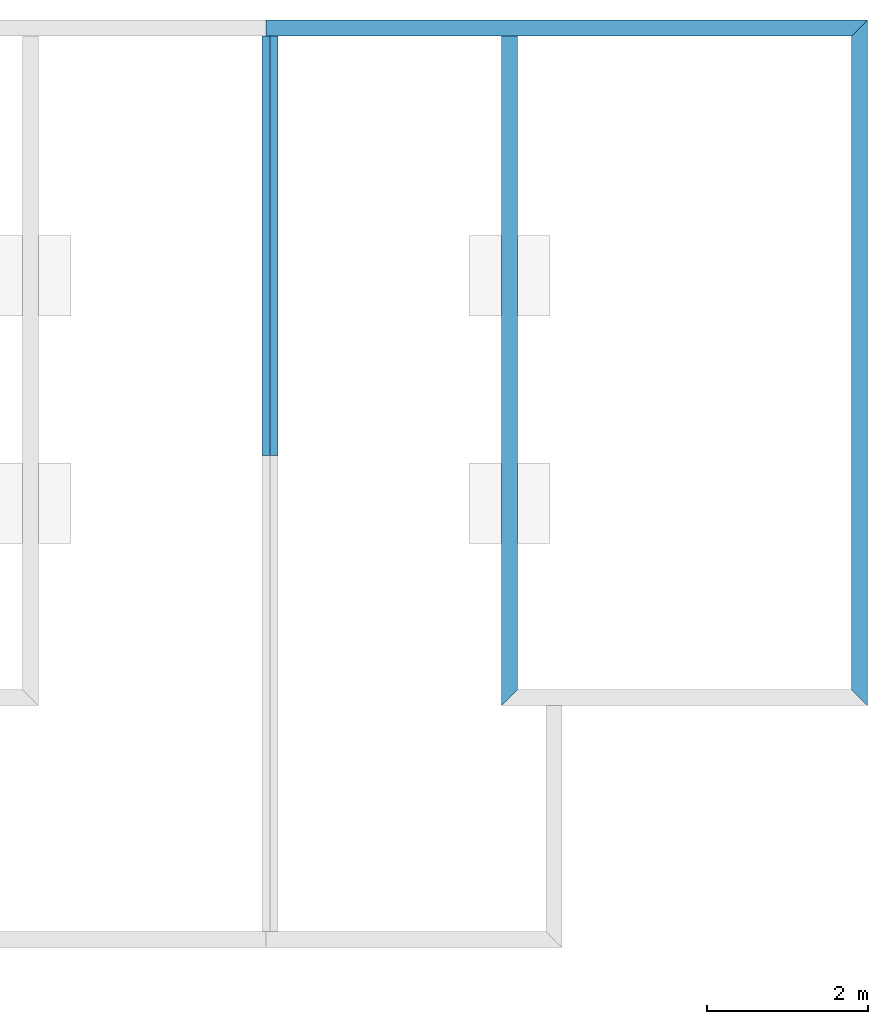
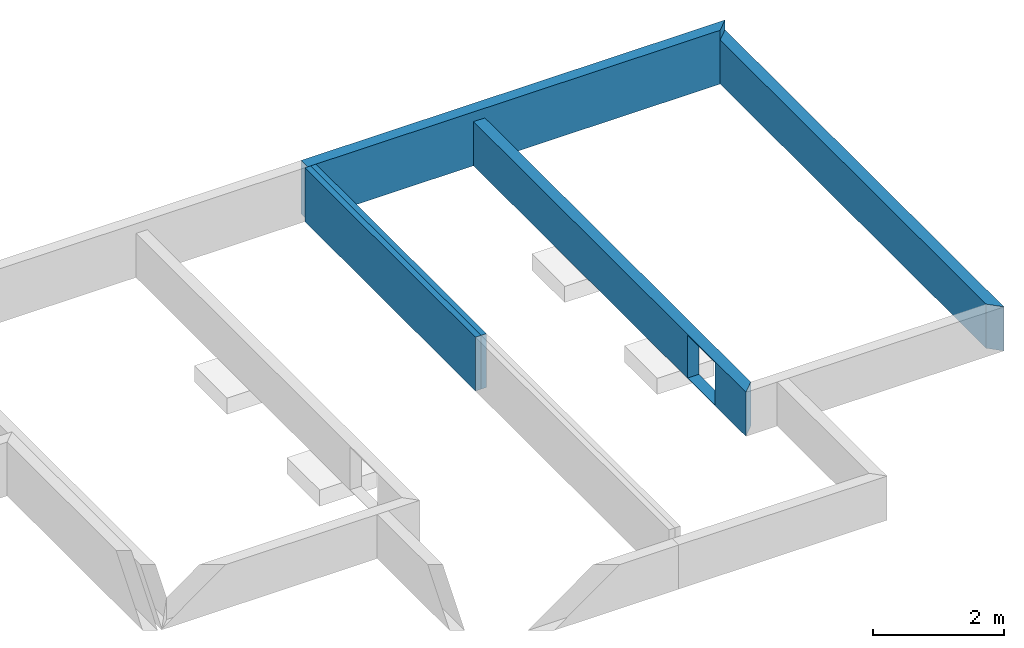
# One storey, part 2 of 2: 5 walls, 1 opening.
"""IFC2X3 building model written with IfcOpenShell, lengths in metres."""

from ifc_helpers import new_model, entity, si_unit, converted_unit, derived_unit, money_unit, direction, frame, origin_with_axes, origin_2d_with_axis, place, context, subcontext, project, spatial, polyline, rectangle, outline, extrude, clip, halfspace, material, layer, layer_set, layer_usage, type_object, element, save


model = new_model("IFC2X3")

# Units and contexts
model_context = context("Model", 3, precision=1e-05, world=origin_with_axes(), true_north=direction((0.0, 1.0)))
body_context = subcontext(model_context, "Body", "Model", "MODEL_VIEW")
ifc_project = project(units=[si_unit("LENGTHUNIT", "METRE"), si_unit("AREAUNIT", "SQUARE_METRE"), si_unit("VOLUMEUNIT", "CUBIC_METRE"), converted_unit("PLANEANGLEUNIT", "DEGREE", entity("IfcPlaneAngleMeasure", 0.0174532925199), si_unit("PLANEANGLEUNIT", "RADIAN"), dimensions=[0, 0, 0, 0, 0, 0, 0]), si_unit("SOLIDANGLEUNIT", "STERADIAN"), money_unit("CHF"), converted_unit("TIMEUNIT", "Year", entity("IfcTimeMeasure", 31556926.0), si_unit("TIMEUNIT", "SECOND"), dimensions=[0, 0, 1, 0, 0, 0, 0]), si_unit("MASSUNIT", "GRAM", prefix="KILO"), si_unit("THERMODYNAMICTEMPERATUREUNIT", "DEGREE_CELSIUS"), si_unit("LUMINOUSINTENSITYUNIT", "LUMEN"), si_unit("ENERGYUNIT", "JOULE", prefix="MEGA"), derived_unit("THERMALCONDUCTANCEUNIT", [(si_unit("POWERUNIT", "WATT"), 1), (si_unit("LENGTHUNIT", "METRE"), -1), (si_unit("THERMODYNAMICTEMPERATUREUNIT", "KELVIN"), -1)]), derived_unit("SPECIFICHEATCAPACITYUNIT", [(si_unit("ENERGYUNIT", "JOULE"), 1), (si_unit("MASSUNIT", "GRAM", prefix="KILO"), -1), (si_unit("THERMODYNAMICTEMPERATUREUNIT", "KELVIN"), -1)]), derived_unit("MASSDENSITYUNIT", [(si_unit("MASSUNIT", "GRAM", prefix="KILO"), 1), (si_unit("VOLUMEUNIT", "CUBIC_METRE"), -1)])], contexts=[model_context])

# Site, building, storey
site_placement = place(None, origin_with_axes())
site = spatial("IfcSite", under=ifc_project, at=site_placement, CompositionType="ELEMENT")
building_placement = place(site_placement, origin_with_axes())
building = spatial("IfcBuilding", under=site, at=building_placement, CompositionType="ELEMENT")
storey_placement = place(building_placement, frame((0.0, 0.0, -0.8), z_axis=(0.0, 0.0, 1.0), x_axis=(1.0, 0.0, 0.0)))
storey = spatial("IfcBuildingStorey", under=building, at=storey_placement, Name="vs", CompositionType="ELEMENT", Elevation=-0.8)

# Walls
ifc_material = material(Name="Parpaing")
ifc_layer_1 = layer(ifc_material, 0.2, ventilated="UNKNOWN")
ifc_layer_set_1 = layer_set([ifc_layer_1], Name="Parpaing 0.2")
ifc_layer_usage_1 = layer_usage(ifc_layer_set_1, "AXIS2", "POSITIVE", -0.1)
wall_type_1 = type_object("IfcWallType", Name="Mur de base:Ext. Parpaing 20", PredefinedType="STANDARD")
wall_1_placement = place(storey_placement, frame((83.6810189554, 92.347523968, -0.2), z_axis=(0.0, 0.0, 1.0), x_axis=(1.0, 0.0, 0.0)))
element("IfcWallStandardCase", 1, at=wall_1_placement, inside=storey, type_object=wall_type_1, material=ifc_layer_usage_1, Name="Mur de base:Ext. Parpaing 20", ObjectType="STANDARD", context=body_context, shape_type="SweptSolid", body=[
    extrude(outline(polyline([(0.0, -0.1), (7.25402976813, -0.1), (7.45402976813, 0.1), (0.0, 0.1), (0.0, -0.1)])), origin_with_axes(), (0.0, 0.0, 1.0), 1.0),
])
ifc_layer_usage_2 = layer_usage(ifc_layer_set_1, "AXIS2", "POSITIVE", -0.1)
wall_2_placement = place(storey_placement, frame((91.0350487235, 92.347523968, -0.2), z_axis=(0.0, 0.0, 1.0), x_axis=(0.0, -1.0, 0.0)))
element("IfcWallStandardCase", 2, at=wall_2_placement, inside=storey, type_object=wall_type_1, material=ifc_layer_usage_2, Name="Mur de base:Ext. Parpaing 20", ObjectType="STANDARD", context=body_context, shape_type="SweptSolid", body=[
    extrude(outline(polyline([(0.1, -0.1), (8.2, -0.1), (8.4, 0.1), (-0.1, 0.1), (0.1, -0.1)])), origin_with_axes(), (0.0, 0.0, 1.0), 0.82),
])

# Wall, opening
ifc_layer_usage_3 = layer_usage(ifc_layer_set_1, "AXIS2", "POSITIVE", -0.1)
wall_3_placement = place(storey_placement, frame((86.696785775, 84.047523968, -0.2), z_axis=(0.0, 0.0, 1.0), x_axis=(0.0, 1.0, 0.0)))
wall_3 = element("IfcWallStandardCase", 3, at=wall_3_placement, inside=storey, type_object=wall_type_1, material=ifc_layer_usage_3, Name="Mur de base:Ext. Parpaing 20", ObjectType="STANDARD", context=body_context, shape_type="Clipping", body=[
    clip(extrude(outline(polyline([(0.1, -0.1), (8.2, -0.1), (8.2, 0.1), (-0.1, 0.1), (0.1, -0.1)])), origin_with_axes(), (0.0, 0.0, 1.0), 0.82), halfspace(frame((0.0, 0.0, 0.82), z_axis=(0.0, 0.0, -1.0), x_axis=(0.0, 1.0, 0.0)), True)),
])
opening_placement = place(wall_3_placement, frame((-84.047523968, 86.696785775, 1.0), z_axis=(0.0, 0.0, 1.0), x_axis=(0.0, -1.0, 0.0)))
element("IfcOpeningElement", 4, at=opening_placement, cuts=wall_3, Name="Mur de base:Ext. Parpaing 20", context=body_context, shape_type="SweptSolid", body=[
    extrude(rectangle(XDim=0.793145708582, YDim=0.840999406834, at=origin_2d_with_axis()), frame((86.796785775, 85.3063667318, -0.596572854291), z_axis=(-1.0, 0.0, 0.0), x_axis=(0.0, 0.0, -1.0)), (0.0, 0.0, 1.0), 0.2),
])

# Walls
ifc_layer_2 = layer(ifc_material, 0.1, ventilated="UNKNOWN")
ifc_layer_set_2 = layer_set([ifc_layer_2], Name="Parpaing 0.1")
ifc_layer_usage_4 = layer_usage(ifc_layer_set_2, "AXIS2", "POSITIVE", -0.05)
wall_type_2 = type_object("IfcWallType", Name="Mur de base:Ext. Parpaing 10", PredefinedType="STANDARD")
wall_4_placement = place(storey_placement, frame((83.776785775, 87.0513363421, -0.2), z_axis=(0.0, 0.0, 1.0), x_axis=(0.0, 1.0, 0.0)))
element("IfcWallStandardCase", 5, at=wall_4_placement, inside=storey, type_object=wall_type_2, material=ifc_layer_usage_4, Name="Mur de base:Ext. Parpaing 10", ObjectType="STANDARD", context=body_context, shape_type="SweptSolid", body=[
    extrude(outline(polyline([(0.0, -0.05), (5.1961876259, -0.05), (5.1961876259, 0.05), (0.0, 0.05), (0.0, -0.05)])), origin_with_axes(), (0.0, 0.0, 1.0), 1.0),
])
ifc_layer_usage_5 = layer_usage(ifc_layer_set_2, "AXIS2", "POSITIVE", -0.05)
wall_5_placement = place(storey_placement, frame((83.6810189554, 87.0513363421, -0.2), z_axis=(0.0, 0.0, 1.0), x_axis=(0.0, 1.0, 0.0)))
element("IfcWallStandardCase", 6, at=wall_5_placement, inside=storey, type_object=wall_type_2, material=ifc_layer_usage_5, Name="Mur de base:Ext. Parpaing 10", ObjectType="STANDARD", context=body_context, shape_type="SweptSolid", body=[
    extrude(outline(polyline([(0.0, -0.05), (5.1961876259, -0.05), (5.1961876259, 0.05), (0.0, 0.05), (0.0, -0.05)])), origin_with_axes(), (0.0, 0.0, 1.0), 1.0),
])

save(model, "model.ifc")
